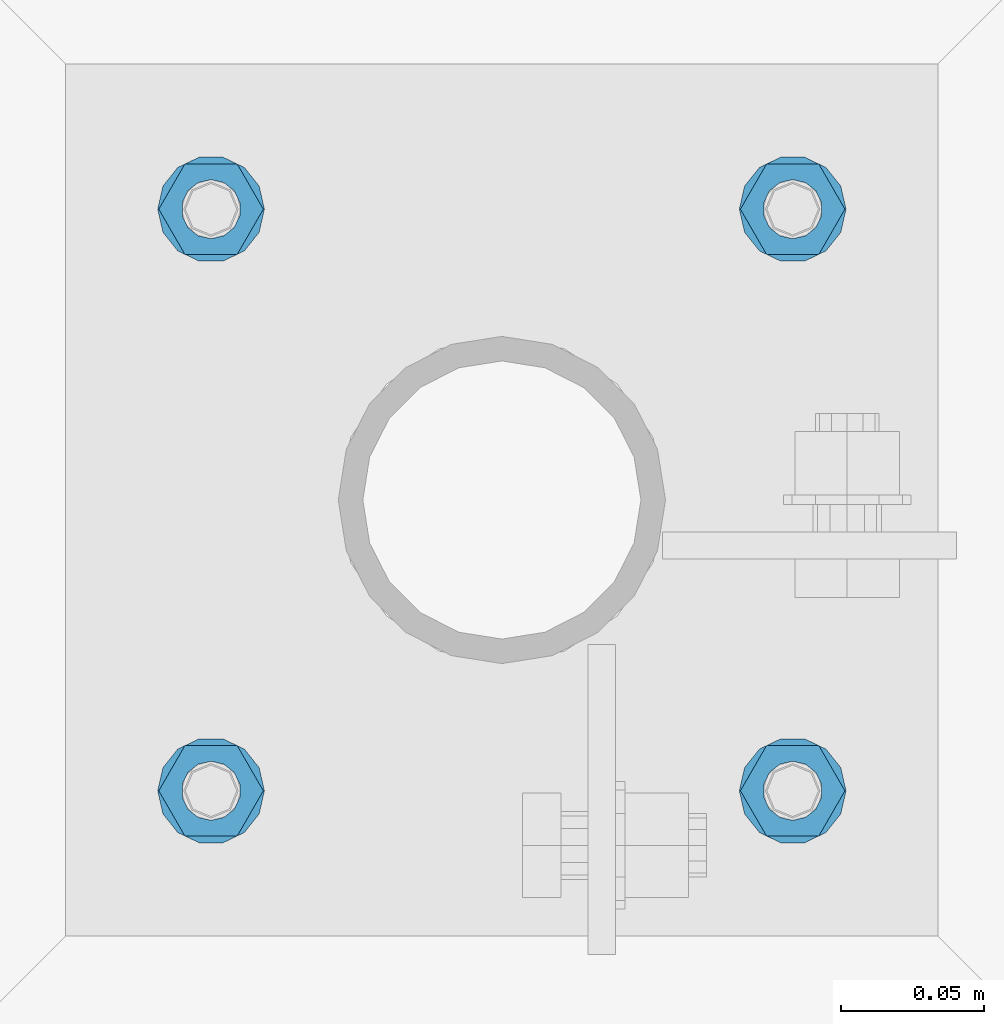
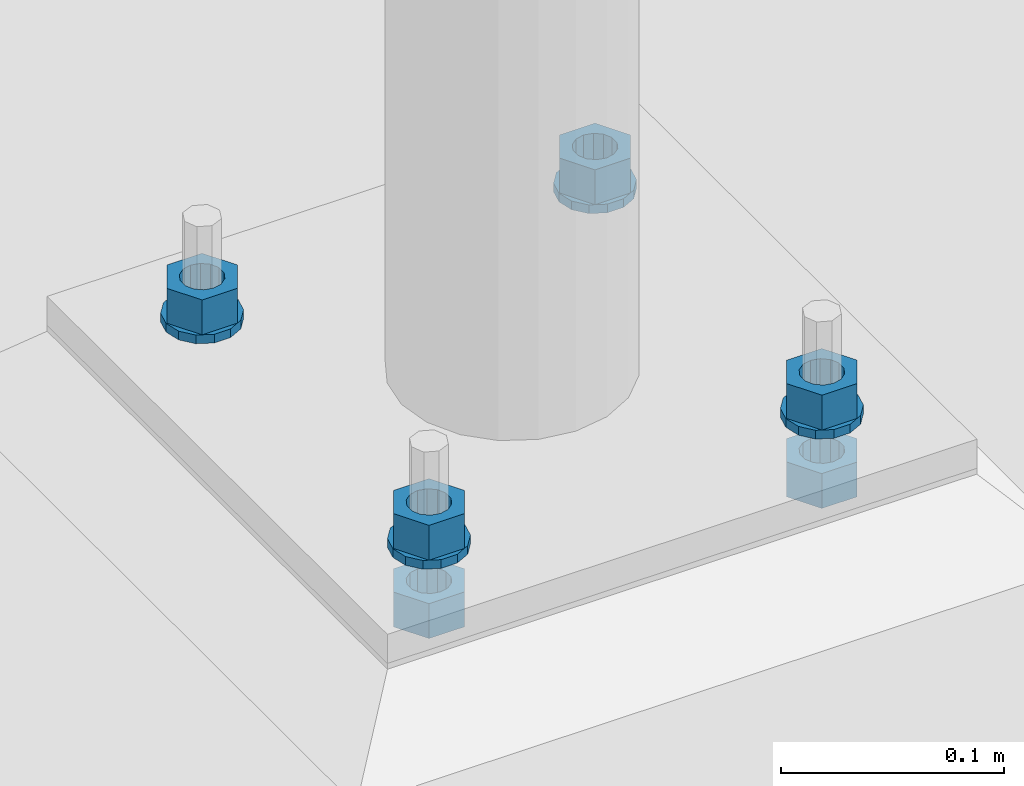
# One storey, part 616 of 975: 10 beams.
"""IFC2X3 building model written with IfcOpenShell, lengths in millimetres."""

from ifc_helpers import new_model, si_unit, frame, origin_with_axes, place, context, subcontext, project, spatial, faceted_brep, material, type_object, element, save


model = new_model("IFC2X3")

# Units and contexts
model_context = context("Model", 3, precision=1e-05, world=origin_with_axes())
body_context = subcontext(model_context, "Body", "Model", "MODEL_VIEW")
ifc_project = project(units=[si_unit("LENGTHUNIT", "METRE", prefix="MILLI"), si_unit("AREAUNIT", "SQUARE_METRE"), si_unit("VOLUMEUNIT", "CUBIC_METRE"), si_unit("MASSUNIT", "GRAM", prefix="KILO"), si_unit("TIMEUNIT", "SECOND"), si_unit("PLANEANGLEUNIT", "RADIAN"), si_unit("SOLIDANGLEUNIT", "STERADIAN"), si_unit("THERMODYNAMICTEMPERATUREUNIT", "DEGREE_CELSIUS"), si_unit("LUMINOUSINTENSITYUNIT", "LUMEN")], contexts=[model_context])

# Site, building, storey
site_placement = place(None, origin_with_axes())
site = spatial("IfcSite", under=ifc_project, at=site_placement, CompositionType="ELEMENT")
building_placement = place(site_placement, origin_with_axes())
building = spatial("IfcBuilding", under=site, at=building_placement, Name="Undefined", CompositionType="ELEMENT")
storey_placement = place(building_placement, origin_with_axes())
storey = spatial("IfcBuildingStorey", under=building, at=storey_placement, Name="Undefined", CompositionType="ELEMENT", Elevation=0.0)

# Beams
ifc_material = material(Name="STEEL/A36")
beam_type_1 = type_object("IfcBeamType", Name="3/4_WASHER", PredefinedType="NOTDEFINED")
beam_1_placement = place(storey_placement, frame((2016.12500152588, 29860.875, -242.887499999999), z_axis=(0.0, -1.0, 0.0), x_axis=(0.0, 0.0, -1.0)))
element("IfcBeam", 1, at=beam_1_placement, inside=storey, type_object=beam_type_1, material=ifc_material, Name="WASHER", ObjectType="3/4_WASHER", context=body_context, shape_type="Brep", body=[
    faceted_brep([(0.0, -18.6499996185303, 0.0), (0.0, -16.8030690426876, -8.09193156902904), (4.76250000000073, -16.8030690426876, -8.09193156902904), (4.76250000000073, -18.6499996185303, 0.0), (0.0, -11.6280845668225, -14.5811568497838), (4.76250000000073, -11.6280845668225, -14.5811568497838), (0.0, -4.15001533340001, -18.1824051902857), (4.76250000000073, -4.15001533340001, -18.1824051902857), (0.0, 4.15001533340001, -18.1824051902857), (4.76250000000073, 4.15001533340001, -18.1824051902857), (0.0, 11.6280845668234, -14.5811568497838), (4.76250000000073, 11.6280845668234, -14.5811568497838), (0.0, 16.8030690426876, -8.09193156902904), (4.76250000000073, 16.8030690426876, -8.09193156902904), (0.0, 18.6499996185303, 0.0), (4.76250000000073, 18.6499996185303, 0.0), (0.0, 16.8030690426876, 8.09193156902904), (4.76250000000073, 16.8030690426876, 8.09193156902904), (0.0, 11.6280845668225, 14.5811568497838), (4.76250000000073, 11.6280845668225, 14.5811568497838), (0.0, 4.15001533340001, 18.1824051902857), (4.76250000000073, 4.15001533340001, 18.1824051902857), (0.0, -4.15001533340001, 18.1824051902857), (4.76250000000073, -4.15001533340001, 18.1824051902857), (0.0, -11.6280845668234, 14.5811568497838), (4.76250000000073, -11.6280845668234, 14.5811568497838), (0.0, -16.8030690426876, 8.09193156902904), (4.76250000000073, -16.8030690426876, 8.09193156902904), (0.0, 0.0, 10.3199996948242), (0.0, 4.47768005528269, 9.29799844179911), (4.76250000000073, 4.47768005528269, 9.29799844179911), (4.76250000000073, 0.0, 10.3199996948242), (0.0, 8.06850066047446, 6.43441456490817), (4.76250000000073, 8.06850066047446, 6.43441456490817), (0.0, 10.0612557561917, 2.29641597052117), (4.76250000000073, 10.0612557561917, 2.29641597052117), (0.0, 10.0612557561917, -2.29641597052117), (4.76250000000073, 10.0612557561917, -2.29641597052117), (0.0, 8.06850066047446, -6.43441456490814), (4.76250000000073, 8.06850066047446, -6.43441456490814), (0.0, 4.47768005528269, -9.29799844179908), (4.76250000000073, 4.47768005528269, -9.29799844179908), (0.0, 0.0, -10.3199996948242), (4.76250000000073, 0.0, -10.3199996948242), (0.0, -4.47768005528269, -9.29799844179911), (4.76250000000073, -4.47768005528269, -9.29799844179911), (0.0, -8.06850066047446, -6.43441456490817), (4.76250000000073, -8.06850066047446, -6.43441456490817), (0.0, -10.0612557561917, -2.29641597052117), (4.76250000000073, -10.0612557561917, -2.29641597052117), (0.0, -10.0612557561917, 2.29641597052117), (4.76250000000073, -10.0612557561917, 2.29641597052117), (0.0, -8.06850066047446, 6.43441456490814), (4.76250000000073, -8.06850066047446, 6.43441456490814), (0.0, -4.47768005528269, 9.29799844179908), (4.76250000000073, -4.47768005528269, 9.29799844179908)], [[[0, 1, 2, 3]], [[1, 4, 5, 2]], [[4, 6, 7, 5]], [[6, 8, 9, 7]], [[8, 10, 11, 9]], [[10, 12, 13, 11]], [[12, 14, 15, 13]], [[14, 16, 17, 15]], [[16, 18, 19, 17]], [[18, 20, 21, 19]], [[20, 22, 23, 21]], [[22, 24, 25, 23]], [[24, 26, 27, 25]], [[26, 0, 3, 27]], [[28, 29, 30, 31]], [[29, 32, 33, 30]], [[32, 34, 35, 33]], [[34, 36, 37, 35]], [[36, 38, 39, 37]], [[38, 40, 41, 39]], [[40, 42, 43, 41]], [[42, 44, 45, 43]], [[44, 46, 47, 45]], [[46, 48, 49, 47]], [[48, 50, 51, 49]], [[50, 52, 53, 51]], [[52, 54, 55, 53]], [[54, 28, 31, 55]], [[5, 7, 9, 11, 13, 15, 17, 19, 21, 23, 25, 27, 3, 2], [33, 35, 37, 39, 41, 43, 45, 47, 49, 51, 53, 55, 31, 30]], [[26, 24, 22, 20, 18, 16, 14, 12, 10, 8, 6, 4, 1, 0], [54, 52, 50, 48, 46, 44, 42, 40, 38, 36, 34, 32, 29, 28]]]),
])
beam_2_placement = place(storey_placement, frame((2219.32499847412, 29860.875, -242.887499999999), z_axis=(0.0, 1.0, 0.0), x_axis=(0.0, 0.0, -1.0)))
element("IfcBeam", 2, at=beam_2_placement, inside=storey, type_object=beam_type_1, material=ifc_material, Name="WASHER", ObjectType="3/4_WASHER", context=body_context, shape_type="Brep", body=[
    faceted_brep([(0.0, -18.6499996185303, 0.0), (0.0, -16.8030690426876, -8.09193156902904), (4.76250000000073, -16.8030690426876, -8.09193156902904), (4.76250000000073, -18.6499996185303, 0.0), (0.0, -11.6280845668225, -14.5811568497838), (4.76250000000073, -11.6280845668225, -14.5811568497838), (0.0, -4.15001533340001, -18.1824051902857), (4.76250000000073, -4.15001533340001, -18.1824051902857), (0.0, 4.15001533340001, -18.1824051902857), (4.76250000000073, 4.15001533340001, -18.1824051902857), (0.0, 11.6280845668234, -14.5811568497838), (4.76250000000073, 11.6280845668234, -14.5811568497838), (0.0, 16.8030690426876, -8.09193156902904), (4.76250000000073, 16.8030690426876, -8.09193156902904), (0.0, 18.6499996185303, 0.0), (4.76250000000073, 18.6499996185303, 0.0), (0.0, 16.8030690426876, 8.09193156902904), (4.76250000000073, 16.8030690426876, 8.09193156902904), (0.0, 11.6280845668225, 14.5811568497838), (4.76250000000073, 11.6280845668225, 14.5811568497838), (0.0, 4.15001533340001, 18.1824051902857), (4.76250000000073, 4.15001533340001, 18.1824051902857), (0.0, -4.15001533340001, 18.1824051902857), (4.76250000000073, -4.15001533340001, 18.1824051902857), (0.0, -11.6280845668234, 14.5811568497838), (4.76250000000073, -11.6280845668234, 14.5811568497838), (0.0, -16.8030690426876, 8.09193156902904), (4.76250000000073, -16.8030690426876, 8.09193156902904), (0.0, 0.0, 10.3199996948242), (0.0, 4.47768005528269, 9.29799844179911), (4.76250000000073, 4.47768005528269, 9.29799844179911), (4.76250000000073, 0.0, 10.3199996948242), (0.0, 8.06850066047446, 6.43441456490817), (4.76250000000073, 8.06850066047446, 6.43441456490817), (0.0, 10.0612557561917, 2.29641597052117), (4.76250000000073, 10.0612557561917, 2.29641597052117), (0.0, 10.0612557561917, -2.29641597052117), (4.76250000000073, 10.0612557561917, -2.29641597052117), (0.0, 8.06850066047446, -6.43441456490814), (4.76250000000073, 8.06850066047446, -6.43441456490814), (0.0, 4.47768005528269, -9.29799844179908), (4.76250000000073, 4.47768005528269, -9.29799844179908), (0.0, 0.0, -10.3199996948242), (4.76250000000073, 0.0, -10.3199996948242), (0.0, -4.47768005528269, -9.29799844179911), (4.76250000000073, -4.47768005528269, -9.29799844179911), (0.0, -8.06850066047446, -6.43441456490817), (4.76250000000073, -8.06850066047446, -6.43441456490817), (0.0, -10.0612557561917, -2.29641597052117), (4.76250000000073, -10.0612557561917, -2.29641597052117), (0.0, -10.0612557561917, 2.29641597052117), (4.76250000000073, -10.0612557561917, 2.29641597052117), (0.0, -8.06850066047446, 6.43441456490814), (4.76250000000073, -8.06850066047446, 6.43441456490814), (0.0, -4.47768005528269, 9.29799844179908), (4.76250000000073, -4.47768005528269, 9.29799844179908)], [[[0, 1, 2, 3]], [[1, 4, 5, 2]], [[4, 6, 7, 5]], [[6, 8, 9, 7]], [[8, 10, 11, 9]], [[10, 12, 13, 11]], [[12, 14, 15, 13]], [[14, 16, 17, 15]], [[16, 18, 19, 17]], [[18, 20, 21, 19]], [[20, 22, 23, 21]], [[22, 24, 25, 23]], [[24, 26, 27, 25]], [[26, 0, 3, 27]], [[28, 29, 30, 31]], [[29, 32, 33, 30]], [[32, 34, 35, 33]], [[34, 36, 37, 35]], [[36, 38, 39, 37]], [[38, 40, 41, 39]], [[40, 42, 43, 41]], [[42, 44, 45, 43]], [[44, 46, 47, 45]], [[46, 48, 49, 47]], [[48, 50, 51, 49]], [[50, 52, 53, 51]], [[52, 54, 55, 53]], [[54, 28, 31, 55]], [[5, 7, 9, 11, 13, 15, 17, 19, 21, 23, 25, 27, 3, 2], [33, 35, 37, 39, 41, 43, 45, 47, 49, 51, 53, 55, 31, 30]], [[26, 24, 22, 20, 18, 16, 14, 12, 10, 8, 6, 4, 1, 0], [54, 52, 50, 48, 46, 44, 42, 40, 38, 36, 34, 32, 29, 28]]]),
])
beam_3_placement = place(storey_placement, frame((2016.12500152588, 30064.0749969482, -242.887499999999), z_axis=(0.0, -1.0, 0.0), x_axis=(0.0, 0.0, -1.0)))
element("IfcBeam", 3, at=beam_3_placement, inside=storey, type_object=beam_type_1, material=ifc_material, Name="WASHER", ObjectType="3/4_WASHER", context=body_context, shape_type="Brep", body=[
    faceted_brep([(0.0, -18.6499996185303, 0.0), (0.0, -16.8030690426876, -8.09193156902904), (4.76250000000073, -16.8030690426876, -8.09193156902904), (4.76250000000073, -18.6499996185303, 0.0), (0.0, -11.6280845668225, -14.5811568497838), (4.76250000000073, -11.6280845668225, -14.5811568497838), (0.0, -4.15001533340001, -18.1824051902857), (4.76250000000073, -4.15001533340001, -18.1824051902857), (0.0, 4.15001533340001, -18.1824051902857), (4.76250000000073, 4.15001533340001, -18.1824051902857), (0.0, 11.6280845668234, -14.5811568497838), (4.76250000000073, 11.6280845668234, -14.5811568497838), (0.0, 16.8030690426876, -8.09193156902904), (4.76250000000073, 16.8030690426876, -8.09193156902904), (0.0, 18.6499996185303, 0.0), (4.76250000000073, 18.6499996185303, 0.0), (0.0, 16.8030690426876, 8.09193156902904), (4.76250000000073, 16.8030690426876, 8.09193156902904), (0.0, 11.6280845668225, 14.5811568497838), (4.76250000000073, 11.6280845668225, 14.5811568497838), (0.0, 4.15001533340001, 18.1824051902857), (4.76250000000073, 4.15001533340001, 18.1824051902857), (0.0, -4.15001533340001, 18.1824051902857), (4.76250000000073, -4.15001533340001, 18.1824051902857), (0.0, -11.6280845668234, 14.5811568497838), (4.76250000000073, -11.6280845668234, 14.5811568497838), (0.0, -16.8030690426876, 8.09193156902904), (4.76250000000073, -16.8030690426876, 8.09193156902904), (0.0, 0.0, 10.3199996948242), (0.0, 4.47768005528269, 9.29799844179911), (4.76250000000073, 4.47768005528269, 9.29799844179911), (4.76250000000073, 0.0, 10.3199996948242), (0.0, 8.06850066047446, 6.43441456490817), (4.76250000000073, 8.06850066047446, 6.43441456490817), (0.0, 10.0612557561917, 2.29641597052117), (4.76250000000073, 10.0612557561917, 2.29641597052117), (0.0, 10.0612557561917, -2.29641597052117), (4.76250000000073, 10.0612557561917, -2.29641597052117), (0.0, 8.06850066047446, -6.43441456490814), (4.76250000000073, 8.06850066047446, -6.43441456490814), (0.0, 4.47768005528269, -9.29799844179908), (4.76250000000073, 4.47768005528269, -9.29799844179908), (0.0, 0.0, -10.3199996948242), (4.76250000000073, 0.0, -10.3199996948242), (0.0, -4.47768005528269, -9.29799844179911), (4.76250000000073, -4.47768005528269, -9.29799844179911), (0.0, -8.06850066047446, -6.43441456490817), (4.76250000000073, -8.06850066047446, -6.43441456490817), (0.0, -10.0612557561917, -2.29641597052117), (4.76250000000073, -10.0612557561917, -2.29641597052117), (0.0, -10.0612557561917, 2.29641597052117), (4.76250000000073, -10.0612557561917, 2.29641597052117), (0.0, -8.06850066047446, 6.43441456490814), (4.76250000000073, -8.06850066047446, 6.43441456490814), (0.0, -4.47768005528269, 9.29799844179908), (4.76250000000073, -4.47768005528269, 9.29799844179908)], [[[0, 1, 2, 3]], [[1, 4, 5, 2]], [[4, 6, 7, 5]], [[6, 8, 9, 7]], [[8, 10, 11, 9]], [[10, 12, 13, 11]], [[12, 14, 15, 13]], [[14, 16, 17, 15]], [[16, 18, 19, 17]], [[18, 20, 21, 19]], [[20, 22, 23, 21]], [[22, 24, 25, 23]], [[24, 26, 27, 25]], [[26, 0, 3, 27]], [[28, 29, 30, 31]], [[29, 32, 33, 30]], [[32, 34, 35, 33]], [[34, 36, 37, 35]], [[36, 38, 39, 37]], [[38, 40, 41, 39]], [[40, 42, 43, 41]], [[42, 44, 45, 43]], [[44, 46, 47, 45]], [[46, 48, 49, 47]], [[48, 50, 51, 49]], [[50, 52, 53, 51]], [[52, 54, 55, 53]], [[54, 28, 31, 55]], [[5, 7, 9, 11, 13, 15, 17, 19, 21, 23, 25, 27, 3, 2], [33, 35, 37, 39, 41, 43, 45, 47, 49, 51, 53, 55, 31, 30]], [[26, 24, 22, 20, 18, 16, 14, 12, 10, 8, 6, 4, 1, 0], [54, 52, 50, 48, 46, 44, 42, 40, 38, 36, 34, 32, 29, 28]]]),
])
beam_4_placement = place(storey_placement, frame((2219.32499847412, 30064.0749969482, -242.887499999999), z_axis=(0.0, 1.0, 0.0), x_axis=(0.0, 0.0, -1.0)))
element("IfcBeam", 4, at=beam_4_placement, inside=storey, type_object=beam_type_1, material=ifc_material, Name="WASHER", ObjectType="3/4_WASHER", context=body_context, shape_type="Brep", body=[
    faceted_brep([(0.0, -18.6499996185303, 0.0), (0.0, -16.8030690426876, -8.09193156902904), (4.76250000000073, -16.8030690426876, -8.09193156902904), (4.76250000000073, -18.6499996185303, 0.0), (0.0, -11.6280845668225, -14.5811568497838), (4.76250000000073, -11.6280845668225, -14.5811568497838), (0.0, -4.15001533340001, -18.1824051902857), (4.76250000000073, -4.15001533340001, -18.1824051902857), (0.0, 4.15001533340001, -18.1824051902857), (4.76250000000073, 4.15001533340001, -18.1824051902857), (0.0, 11.6280845668234, -14.5811568497838), (4.76250000000073, 11.6280845668234, -14.5811568497838), (0.0, 16.8030690426876, -8.09193156902904), (4.76250000000073, 16.8030690426876, -8.09193156902904), (0.0, 18.6499996185303, 0.0), (4.76250000000073, 18.6499996185303, 0.0), (0.0, 16.8030690426876, 8.09193156902904), (4.76250000000073, 16.8030690426876, 8.09193156902904), (0.0, 11.6280845668225, 14.5811568497838), (4.76250000000073, 11.6280845668225, 14.5811568497838), (0.0, 4.15001533340001, 18.1824051902857), (4.76250000000073, 4.15001533340001, 18.1824051902857), (0.0, -4.15001533340001, 18.1824051902857), (4.76250000000073, -4.15001533340001, 18.1824051902857), (0.0, -11.6280845668234, 14.5811568497838), (4.76250000000073, -11.6280845668234, 14.5811568497838), (0.0, -16.8030690426876, 8.09193156902904), (4.76250000000073, -16.8030690426876, 8.09193156902904), (0.0, 0.0, 10.3199996948242), (0.0, 4.47768005528269, 9.29799844179911), (4.76250000000073, 4.47768005528269, 9.29799844179911), (4.76250000000073, 0.0, 10.3199996948242), (0.0, 8.06850066047446, 6.43441456490817), (4.76250000000073, 8.06850066047446, 6.43441456490817), (0.0, 10.0612557561917, 2.29641597052117), (4.76250000000073, 10.0612557561917, 2.29641597052117), (0.0, 10.0612557561917, -2.29641597052117), (4.76250000000073, 10.0612557561917, -2.29641597052117), (0.0, 8.06850066047446, -6.43441456490814), (4.76250000000073, 8.06850066047446, -6.43441456490814), (0.0, 4.47768005528269, -9.29799844179908), (4.76250000000073, 4.47768005528269, -9.29799844179908), (0.0, 0.0, -10.3199996948242), (4.76250000000073, 0.0, -10.3199996948242), (0.0, -4.47768005528269, -9.29799844179911), (4.76250000000073, -4.47768005528269, -9.29799844179911), (0.0, -8.06850066047446, -6.43441456490817), (4.76250000000073, -8.06850066047446, -6.43441456490817), (0.0, -10.0612557561917, -2.29641597052117), (4.76250000000073, -10.0612557561917, -2.29641597052117), (0.0, -10.0612557561917, 2.29641597052117), (4.76250000000073, -10.0612557561917, 2.29641597052117), (0.0, -8.06850066047446, 6.43441456490814), (4.76250000000073, -8.06850066047446, 6.43441456490814), (0.0, -4.47768005528269, 9.29799844179908), (4.76250000000073, -4.47768005528269, 9.29799844179908)], [[[0, 1, 2, 3]], [[1, 4, 5, 2]], [[4, 6, 7, 5]], [[6, 8, 9, 7]], [[8, 10, 11, 9]], [[10, 12, 13, 11]], [[12, 14, 15, 13]], [[14, 16, 17, 15]], [[16, 18, 19, 17]], [[18, 20, 21, 19]], [[20, 22, 23, 21]], [[22, 24, 25, 23]], [[24, 26, 27, 25]], [[26, 0, 3, 27]], [[28, 29, 30, 31]], [[29, 32, 33, 30]], [[32, 34, 35, 33]], [[34, 36, 37, 35]], [[36, 38, 39, 37]], [[38, 40, 41, 39]], [[40, 42, 43, 41]], [[42, 44, 45, 43]], [[44, 46, 47, 45]], [[46, 48, 49, 47]], [[48, 50, 51, 49]], [[50, 52, 53, 51]], [[52, 54, 55, 53]], [[54, 28, 31, 55]], [[5, 7, 9, 11, 13, 15, 17, 19, 21, 23, 25, 27, 3, 2], [33, 35, 37, 39, 41, 43, 45, 47, 49, 51, 53, 55, 31, 30]], [[26, 24, 22, 20, 18, 16, 14, 12, 10, 8, 6, 4, 1, 0], [54, 52, 50, 48, 46, 44, 42, 40, 38, 36, 34, 32, 29, 28]]]),
])
beam_type_2 = type_object("IfcBeamType", Name="3/4_HEAVY_HEX_NUT", PredefinedType="NOTDEFINED")
beam_5_placement = place(storey_placement, frame((2016.12500152588, 29860.875, -223.8375), z_axis=(0.0, -1.0, 0.0), x_axis=(0.0, 0.0, -1.0)))
element("IfcBeam", 5, at=beam_5_placement, inside=storey, type_object=beam_type_2, material=ifc_material, Name="NUT", ObjectType="3/4_HEAVY_HEX_NUT", context=body_context, shape_type="Brep", body=[
    faceted_brep([(0.0, -18.2600002288818, 0.0), (0.0, -9.13000011444092, -15.8100004196167), (19.0499999999993, -9.13000011444092, -15.8100004196167), (19.0499999999993, -18.2600002288818, 0.0), (0.0, 9.13000011444092, -15.8100004196167), (19.0499999999993, 9.13000011444092, -15.8100004196167), (0.0, 18.2600002288818, 0.0), (19.0499999999993, 18.2600002288818, 0.0), (0.0, 9.13000011444092, 15.8100004196167), (19.0499999999993, 9.13000011444092, 15.8100004196167), (0.0, -9.13000011444092, 15.8100004196167), (19.0499999999993, -9.13000011444092, 15.8100004196167), (0.0, 0.0, 10.3199996948242), (0.0, 4.47768005528269, 9.29799844179911), (19.0499999999993, 4.47768005528269, 9.29799844179911), (19.0499999999993, 0.0, 10.3199996948242), (0.0, 8.06850066047446, 6.43441456490817), (19.0499999999993, 8.06850066047446, 6.43441456490817), (0.0, 10.0612557561917, 2.29641597052117), (19.0499999999993, 10.0612557561917, 2.29641597052117), (0.0, 10.0612557561917, -2.29641597052117), (19.0499999999993, 10.0612557561917, -2.29641597052117), (0.0, 8.06850066047446, -6.43441456490814), (19.0499999999993, 8.06850066047446, -6.43441456490814), (0.0, 4.47768005528269, -9.29799844179908), (19.0499999999993, 4.47768005528269, -9.29799844179908), (0.0, 0.0, -10.3199996948242), (19.0499999999993, 0.0, -10.3199996948242), (0.0, -4.47768005528269, -9.29799844179911), (19.0499999999993, -4.47768005528269, -9.29799844179911), (0.0, -8.06850066047446, -6.43441456490817), (19.0499999999993, -8.06850066047446, -6.43441456490817), (0.0, -10.0612557561917, -2.29641597052117), (19.0499999999993, -10.0612557561917, -2.29641597052117), (0.0, -10.0612557561917, 2.29641597052117), (19.0499999999993, -10.0612557561917, 2.29641597052117), (0.0, -8.06850066047446, 6.43441456490814), (19.0499999999993, -8.06850066047446, 6.43441456490814), (0.0, -4.47768005528269, 9.29799844179908), (19.0499999999993, -4.47768005528269, 9.29799844179908)], [[[0, 1, 2, 3]], [[1, 4, 5, 2]], [[4, 6, 7, 5]], [[6, 8, 9, 7]], [[8, 10, 11, 9]], [[10, 0, 3, 11]], [[12, 13, 14, 15]], [[13, 16, 17, 14]], [[16, 18, 19, 17]], [[18, 20, 21, 19]], [[20, 22, 23, 21]], [[22, 24, 25, 23]], [[24, 26, 27, 25]], [[26, 28, 29, 27]], [[28, 30, 31, 29]], [[30, 32, 33, 31]], [[32, 34, 35, 33]], [[34, 36, 37, 35]], [[36, 38, 39, 37]], [[38, 12, 15, 39]], [[5, 7, 9, 11, 3, 2], [17, 19, 21, 23, 25, 27, 29, 31, 33, 35, 37, 39, 15, 14]], [[10, 8, 6, 4, 1, 0], [38, 36, 34, 32, 30, 28, 26, 24, 22, 20, 18, 16, 13, 12]]]),
])
beam_6_placement = place(storey_placement, frame((2219.32499847412, 29860.875, -223.8375), z_axis=(0.0, 1.0, 0.0), x_axis=(0.0, 0.0, -1.0)))
element("IfcBeam", 6, at=beam_6_placement, inside=storey, type_object=beam_type_2, material=ifc_material, Name="NUT", ObjectType="3/4_HEAVY_HEX_NUT", context=body_context, shape_type="Brep", body=[
    faceted_brep([(0.0, -18.2600002288818, 0.0), (0.0, -9.13000011444092, -15.8100004196167), (19.0499999999993, -9.13000011444092, -15.8100004196167), (19.0499999999993, -18.2600002288818, 0.0), (0.0, 9.13000011444092, -15.8100004196167), (19.0499999999993, 9.13000011444092, -15.8100004196167), (0.0, 18.2600002288818, 0.0), (19.0499999999993, 18.2600002288818, 0.0), (0.0, 9.13000011444092, 15.8100004196167), (19.0499999999993, 9.13000011444092, 15.8100004196167), (0.0, -9.13000011444092, 15.8100004196167), (19.0499999999993, -9.13000011444092, 15.8100004196167), (0.0, 0.0, 10.3199996948242), (0.0, 4.47768005528269, 9.29799844179911), (19.0499999999993, 4.47768005528269, 9.29799844179911), (19.0499999999993, 0.0, 10.3199996948242), (0.0, 8.06850066047446, 6.43441456490817), (19.0499999999993, 8.06850066047446, 6.43441456490817), (0.0, 10.0612557561917, 2.29641597052117), (19.0499999999993, 10.0612557561917, 2.29641597052117), (0.0, 10.0612557561917, -2.29641597052117), (19.0499999999993, 10.0612557561917, -2.29641597052117), (0.0, 8.06850066047446, -6.43441456490814), (19.0499999999993, 8.06850066047446, -6.43441456490814), (0.0, 4.47768005528269, -9.29799844179908), (19.0499999999993, 4.47768005528269, -9.29799844179908), (0.0, 0.0, -10.3199996948242), (19.0499999999993, 0.0, -10.3199996948242), (0.0, -4.47768005528269, -9.29799844179911), (19.0499999999993, -4.47768005528269, -9.29799844179911), (0.0, -8.06850066047446, -6.43441456490817), (19.0499999999993, -8.06850066047446, -6.43441456490817), (0.0, -10.0612557561917, -2.29641597052117), (19.0499999999993, -10.0612557561917, -2.29641597052117), (0.0, -10.0612557561917, 2.29641597052117), (19.0499999999993, -10.0612557561917, 2.29641597052117), (0.0, -8.06850066047446, 6.43441456490814), (19.0499999999993, -8.06850066047446, 6.43441456490814), (0.0, -4.47768005528269, 9.29799844179908), (19.0499999999993, -4.47768005528269, 9.29799844179908)], [[[0, 1, 2, 3]], [[1, 4, 5, 2]], [[4, 6, 7, 5]], [[6, 8, 9, 7]], [[8, 10, 11, 9]], [[10, 0, 3, 11]], [[12, 13, 14, 15]], [[13, 16, 17, 14]], [[16, 18, 19, 17]], [[18, 20, 21, 19]], [[20, 22, 23, 21]], [[22, 24, 25, 23]], [[24, 26, 27, 25]], [[26, 28, 29, 27]], [[28, 30, 31, 29]], [[30, 32, 33, 31]], [[32, 34, 35, 33]], [[34, 36, 37, 35]], [[36, 38, 39, 37]], [[38, 12, 15, 39]], [[5, 7, 9, 11, 3, 2], [17, 19, 21, 23, 25, 27, 29, 31, 33, 35, 37, 39, 15, 14]], [[10, 8, 6, 4, 1, 0], [38, 36, 34, 32, 30, 28, 26, 24, 22, 20, 18, 16, 13, 12]]]),
])
beam_7_placement = place(storey_placement, frame((2016.12500152588, 30064.0749969482, -223.8375), z_axis=(0.0, -1.0, 0.0), x_axis=(0.0, 0.0, -1.0)))
element("IfcBeam", 7, at=beam_7_placement, inside=storey, type_object=beam_type_2, material=ifc_material, Name="NUT", ObjectType="3/4_HEAVY_HEX_NUT", context=body_context, shape_type="Brep", body=[
    faceted_brep([(0.0, -18.2600002288818, 0.0), (0.0, -9.13000011444092, -15.8100004196167), (19.0499999999993, -9.13000011444092, -15.8100004196167), (19.0499999999993, -18.2600002288818, 0.0), (0.0, 9.13000011444092, -15.8100004196167), (19.0499999999993, 9.13000011444092, -15.8100004196167), (0.0, 18.2600002288818, 0.0), (19.0499999999993, 18.2600002288818, 0.0), (0.0, 9.13000011444092, 15.8100004196167), (19.0499999999993, 9.13000011444092, 15.8100004196167), (0.0, -9.13000011444092, 15.8100004196167), (19.0499999999993, -9.13000011444092, 15.8100004196167), (0.0, 0.0, 10.3199996948242), (0.0, 4.47768005528269, 9.29799844179911), (19.0499999999993, 4.47768005528269, 9.29799844179911), (19.0499999999993, 0.0, 10.3199996948242), (0.0, 8.06850066047446, 6.43441456490817), (19.0499999999993, 8.06850066047446, 6.43441456490817), (0.0, 10.0612557561917, 2.29641597052117), (19.0499999999993, 10.0612557561917, 2.29641597052117), (0.0, 10.0612557561917, -2.29641597052117), (19.0499999999993, 10.0612557561917, -2.29641597052117), (0.0, 8.06850066047446, -6.43441456490814), (19.0499999999993, 8.06850066047446, -6.43441456490814), (0.0, 4.47768005528269, -9.29799844179908), (19.0499999999993, 4.47768005528269, -9.29799844179908), (0.0, 0.0, -10.3199996948242), (19.0499999999993, 0.0, -10.3199996948242), (0.0, -4.47768005528269, -9.29799844179911), (19.0499999999993, -4.47768005528269, -9.29799844179911), (0.0, -8.06850066047446, -6.43441456490817), (19.0499999999993, -8.06850066047446, -6.43441456490817), (0.0, -10.0612557561917, -2.29641597052117), (19.0499999999993, -10.0612557561917, -2.29641597052117), (0.0, -10.0612557561917, 2.29641597052117), (19.0499999999993, -10.0612557561917, 2.29641597052117), (0.0, -8.06850066047446, 6.43441456490814), (19.0499999999993, -8.06850066047446, 6.43441456490814), (0.0, -4.47768005528269, 9.29799844179908), (19.0499999999993, -4.47768005528269, 9.29799844179908)], [[[0, 1, 2, 3]], [[1, 4, 5, 2]], [[4, 6, 7, 5]], [[6, 8, 9, 7]], [[8, 10, 11, 9]], [[10, 0, 3, 11]], [[12, 13, 14, 15]], [[13, 16, 17, 14]], [[16, 18, 19, 17]], [[18, 20, 21, 19]], [[20, 22, 23, 21]], [[22, 24, 25, 23]], [[24, 26, 27, 25]], [[26, 28, 29, 27]], [[28, 30, 31, 29]], [[30, 32, 33, 31]], [[32, 34, 35, 33]], [[34, 36, 37, 35]], [[36, 38, 39, 37]], [[38, 12, 15, 39]], [[5, 7, 9, 11, 3, 2], [17, 19, 21, 23, 25, 27, 29, 31, 33, 35, 37, 39, 15, 14]], [[10, 8, 6, 4, 1, 0], [38, 36, 34, 32, 30, 28, 26, 24, 22, 20, 18, 16, 13, 12]]]),
])
beam_8_placement = place(storey_placement, frame((2219.32499847412, 30064.0749969482, -223.8375), z_axis=(0.0, 1.0, 0.0), x_axis=(0.0, 0.0, -1.0)))
element("IfcBeam", 8, at=beam_8_placement, inside=storey, type_object=beam_type_2, material=ifc_material, Name="NUT", ObjectType="3/4_HEAVY_HEX_NUT", context=body_context, shape_type="Brep", body=[
    faceted_brep([(0.0, -18.2600002288818, 0.0), (0.0, -9.13000011444092, -15.8100004196167), (19.0499999999993, -9.13000011444092, -15.8100004196167), (19.0499999999993, -18.2600002288818, 0.0), (0.0, 9.13000011444092, -15.8100004196167), (19.0499999999993, 9.13000011444092, -15.8100004196167), (0.0, 18.2600002288818, 0.0), (19.0499999999993, 18.2600002288818, 0.0), (0.0, 9.13000011444092, 15.8100004196167), (19.0499999999993, 9.13000011444092, 15.8100004196167), (0.0, -9.13000011444092, 15.8100004196167), (19.0499999999993, -9.13000011444092, 15.8100004196167), (0.0, 0.0, 10.3199996948242), (0.0, 4.47768005528269, 9.29799844179911), (19.0499999999993, 4.47768005528269, 9.29799844179911), (19.0499999999993, 0.0, 10.3199996948242), (0.0, 8.06850066047446, 6.43441456490817), (19.0499999999993, 8.06850066047446, 6.43441456490817), (0.0, 10.0612557561917, 2.29641597052117), (19.0499999999993, 10.0612557561917, 2.29641597052117), (0.0, 10.0612557561917, -2.29641597052117), (19.0499999999993, 10.0612557561917, -2.29641597052117), (0.0, 8.06850066047446, -6.43441456490814), (19.0499999999993, 8.06850066047446, -6.43441456490814), (0.0, 4.47768005528269, -9.29799844179908), (19.0499999999993, 4.47768005528269, -9.29799844179908), (0.0, 0.0, -10.3199996948242), (19.0499999999993, 0.0, -10.3199996948242), (0.0, -4.47768005528269, -9.29799844179911), (19.0499999999993, -4.47768005528269, -9.29799844179911), (0.0, -8.06850066047446, -6.43441456490817), (19.0499999999993, -8.06850066047446, -6.43441456490817), (0.0, -10.0612557561917, -2.29641597052117), (19.0499999999993, -10.0612557561917, -2.29641597052117), (0.0, -10.0612557561917, 2.29641597052117), (19.0499999999993, -10.0612557561917, 2.29641597052117), (0.0, -8.06850066047446, 6.43441456490814), (19.0499999999993, -8.06850066047446, 6.43441456490814), (0.0, -4.47768005528269, 9.29799844179908), (19.0499999999993, -4.47768005528269, 9.29799844179908)], [[[0, 1, 2, 3]], [[1, 4, 5, 2]], [[4, 6, 7, 5]], [[6, 8, 9, 7]], [[8, 10, 11, 9]], [[10, 0, 3, 11]], [[12, 13, 14, 15]], [[13, 16, 17, 14]], [[16, 18, 19, 17]], [[18, 20, 21, 19]], [[20, 22, 23, 21]], [[22, 24, 25, 23]], [[24, 26, 27, 25]], [[26, 28, 29, 27]], [[28, 30, 31, 29]], [[30, 32, 33, 31]], [[32, 34, 35, 33]], [[34, 36, 37, 35]], [[36, 38, 39, 37]], [[38, 12, 15, 39]], [[5, 7, 9, 11, 3, 2], [17, 19, 21, 23, 25, 27, 29, 31, 33, 35, 37, 39, 15, 14]], [[10, 8, 6, 4, 1, 0], [38, 36, 34, 32, 30, 28, 26, 24, 22, 20, 18, 16, 13, 12]]]),
])
beam_9_placement = place(storey_placement, frame((2016.12500152588, 29860.875, -266.699999999999), z_axis=(0.0, -1.0, 0.0), x_axis=(0.0, 0.0, -1.0)))
element("IfcBeam", 9, at=beam_9_placement, inside=storey, type_object=beam_type_2, material=ifc_material, Name="NUT", ObjectType="3/4_HEAVY_HEX_NUT", context=body_context, shape_type="Brep", body=[
    faceted_brep([(0.0, -18.2600002288818, 0.0), (0.0, -9.13000011444092, -15.8100004196167), (19.0499999999993, -9.13000011444092, -15.8100004196167), (19.0499999999993, -18.2600002288818, 0.0), (0.0, 9.13000011444092, -15.8100004196167), (19.0499999999993, 9.13000011444092, -15.8100004196167), (0.0, 18.2600002288818, 0.0), (19.0499999999993, 18.2600002288818, 0.0), (0.0, 9.13000011444092, 15.8100004196167), (19.0499999999993, 9.13000011444092, 15.8100004196167), (0.0, -9.13000011444092, 15.8100004196167), (19.0499999999993, -9.13000011444092, 15.8100004196167), (0.0, 0.0, 10.3199996948242), (0.0, 4.47768005528269, 9.29799844179911), (19.0499999999993, 4.47768005528269, 9.29799844179911), (19.0499999999993, 0.0, 10.3199996948242), (0.0, 8.06850066047446, 6.43441456490817), (19.0499999999993, 8.06850066047446, 6.43441456490817), (0.0, 10.0612557561917, 2.29641597052117), (19.0499999999993, 10.0612557561917, 2.29641597052117), (0.0, 10.0612557561917, -2.29641597052117), (19.0499999999993, 10.0612557561917, -2.29641597052117), (0.0, 8.06850066047446, -6.43441456490814), (19.0499999999993, 8.06850066047446, -6.43441456490814), (0.0, 4.47768005528269, -9.29799844179908), (19.0499999999993, 4.47768005528269, -9.29799844179908), (0.0, 0.0, -10.3199996948242), (19.0499999999993, 0.0, -10.3199996948242), (0.0, -4.47768005528269, -9.29799844179911), (19.0499999999993, -4.47768005528269, -9.29799844179911), (0.0, -8.06850066047446, -6.43441456490817), (19.0499999999993, -8.06850066047446, -6.43441456490817), (0.0, -10.0612557561917, -2.29641597052117), (19.0499999999993, -10.0612557561917, -2.29641597052117), (0.0, -10.0612557561917, 2.29641597052117), (19.0499999999993, -10.0612557561917, 2.29641597052117), (0.0, -8.06850066047446, 6.43441456490814), (19.0499999999993, -8.06850066047446, 6.43441456490814), (0.0, -4.47768005528269, 9.29799844179908), (19.0499999999993, -4.47768005528269, 9.29799844179908)], [[[0, 1, 2, 3]], [[1, 4, 5, 2]], [[4, 6, 7, 5]], [[6, 8, 9, 7]], [[8, 10, 11, 9]], [[10, 0, 3, 11]], [[12, 13, 14, 15]], [[13, 16, 17, 14]], [[16, 18, 19, 17]], [[18, 20, 21, 19]], [[20, 22, 23, 21]], [[22, 24, 25, 23]], [[24, 26, 27, 25]], [[26, 28, 29, 27]], [[28, 30, 31, 29]], [[30, 32, 33, 31]], [[32, 34, 35, 33]], [[34, 36, 37, 35]], [[36, 38, 39, 37]], [[38, 12, 15, 39]], [[5, 7, 9, 11, 3, 2], [17, 19, 21, 23, 25, 27, 29, 31, 33, 35, 37, 39, 15, 14]], [[10, 8, 6, 4, 1, 0], [38, 36, 34, 32, 30, 28, 26, 24, 22, 20, 18, 16, 13, 12]]]),
])
beam_10_placement = place(storey_placement, frame((2219.32499847412, 29860.875, -266.699999999999), z_axis=(0.0, 1.0, 0.0), x_axis=(0.0, 0.0, -1.0)))
element("IfcBeam", 10, at=beam_10_placement, inside=storey, type_object=beam_type_2, material=ifc_material, Name="NUT", ObjectType="3/4_HEAVY_HEX_NUT", context=body_context, shape_type="Brep", body=[
    faceted_brep([(0.0, -18.2600002288818, 0.0), (0.0, -9.13000011444092, -15.8100004196167), (19.0499999999993, -9.13000011444092, -15.8100004196167), (19.0499999999993, -18.2600002288818, 0.0), (0.0, 9.13000011444092, -15.8100004196167), (19.0499999999993, 9.13000011444092, -15.8100004196167), (0.0, 18.2600002288818, 0.0), (19.0499999999993, 18.2600002288818, 0.0), (0.0, 9.13000011444092, 15.8100004196167), (19.0499999999993, 9.13000011444092, 15.8100004196167), (0.0, -9.13000011444092, 15.8100004196167), (19.0499999999993, -9.13000011444092, 15.8100004196167), (0.0, 0.0, 10.3199996948242), (0.0, 4.47768005528269, 9.29799844179911), (19.0499999999993, 4.47768005528269, 9.29799844179911), (19.0499999999993, 0.0, 10.3199996948242), (0.0, 8.06850066047446, 6.43441456490817), (19.0499999999993, 8.06850066047446, 6.43441456490817), (0.0, 10.0612557561917, 2.29641597052117), (19.0499999999993, 10.0612557561917, 2.29641597052117), (0.0, 10.0612557561917, -2.29641597052117), (19.0499999999993, 10.0612557561917, -2.29641597052117), (0.0, 8.06850066047446, -6.43441456490814), (19.0499999999993, 8.06850066047446, -6.43441456490814), (0.0, 4.47768005528269, -9.29799844179908), (19.0499999999993, 4.47768005528269, -9.29799844179908), (0.0, 0.0, -10.3199996948242), (19.0499999999993, 0.0, -10.3199996948242), (0.0, -4.47768005528269, -9.29799844179911), (19.0499999999993, -4.47768005528269, -9.29799844179911), (0.0, -8.06850066047446, -6.43441456490817), (19.0499999999993, -8.06850066047446, -6.43441456490817), (0.0, -10.0612557561917, -2.29641597052117), (19.0499999999993, -10.0612557561917, -2.29641597052117), (0.0, -10.0612557561917, 2.29641597052117), (19.0499999999993, -10.0612557561917, 2.29641597052117), (0.0, -8.06850066047446, 6.43441456490814), (19.0499999999993, -8.06850066047446, 6.43441456490814), (0.0, -4.47768005528269, 9.29799844179908), (19.0499999999993, -4.47768005528269, 9.29799844179908)], [[[0, 1, 2, 3]], [[1, 4, 5, 2]], [[4, 6, 7, 5]], [[6, 8, 9, 7]], [[8, 10, 11, 9]], [[10, 0, 3, 11]], [[12, 13, 14, 15]], [[13, 16, 17, 14]], [[16, 18, 19, 17]], [[18, 20, 21, 19]], [[20, 22, 23, 21]], [[22, 24, 25, 23]], [[24, 26, 27, 25]], [[26, 28, 29, 27]], [[28, 30, 31, 29]], [[30, 32, 33, 31]], [[32, 34, 35, 33]], [[34, 36, 37, 35]], [[36, 38, 39, 37]], [[38, 12, 15, 39]], [[5, 7, 9, 11, 3, 2], [17, 19, 21, 23, 25, 27, 29, 31, 33, 35, 37, 39, 15, 14]], [[10, 8, 6, 4, 1, 0], [38, 36, 34, 32, 30, 28, 26, 24, 22, 20, 18, 16, 13, 12]]]),
])

save(model, "model.ifc")
